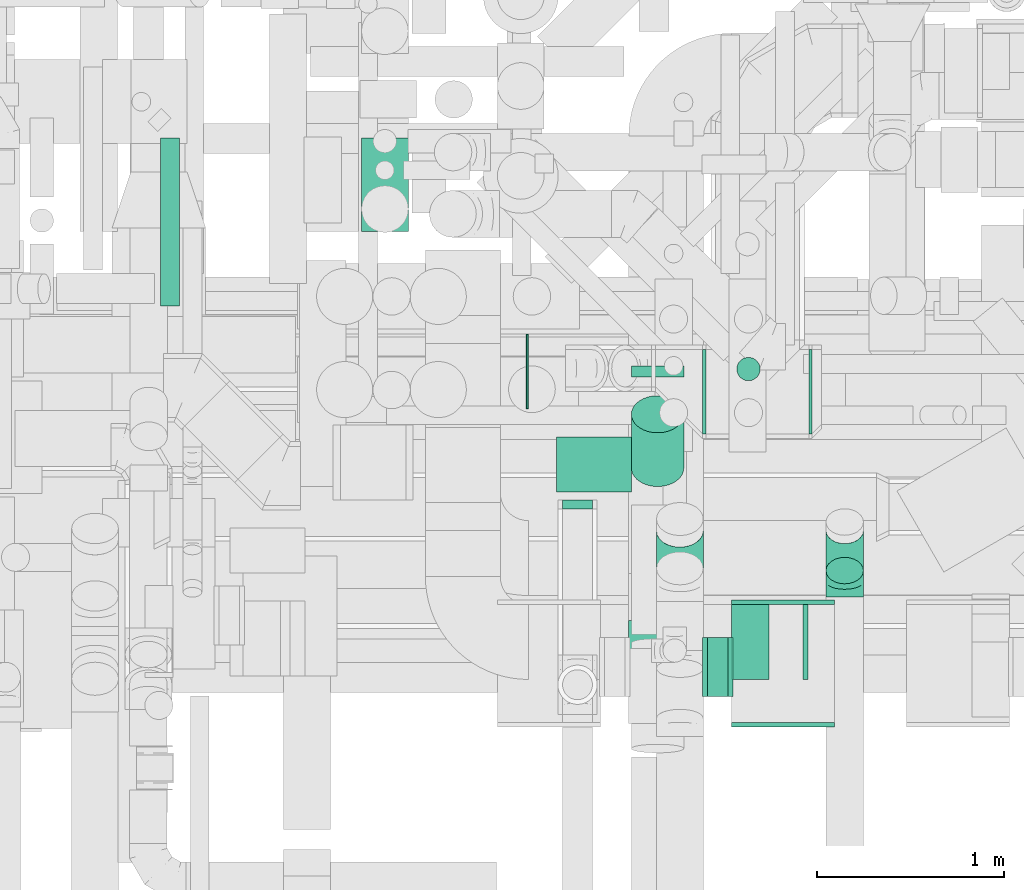
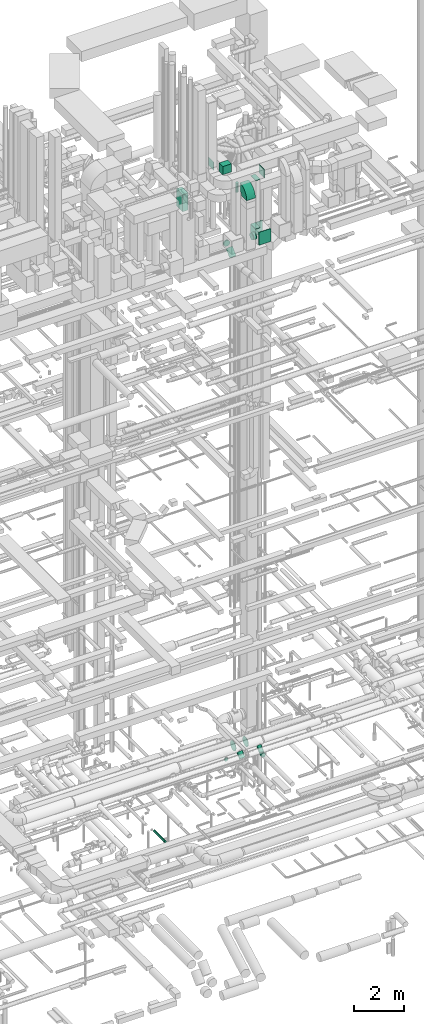
# One storey, part 223 of 337: 12 flow segments, 10 flow fittings.
"""IFC2X3 building model written with IfcOpenShell, lengths in millimetres."""

from ifc_helpers import new_model, entity, si_unit, converted_unit, derived_unit, direction, frame, frame_2d, origin, origin_2d_with_axis, place, context, subcontext, project, spatial, polyline, circle_curve, parameter, trimmed, segment, composite_curve, rectangle, circle, outline, extrude, faceted_brep, source, transform, mapped, material, type_object, type_shapes, element, save


model = new_model("IFC2X3")

# Units and contexts
model_context = context("Model", 3, precision=0.01, world=origin(), true_north=direction((6.12303176911189e-17, 1.0)))
body_context = subcontext(model_context, "Body", "Model", "MODEL_VIEW")
ifc_project = project(units=[si_unit("LENGTHUNIT", "METRE", prefix="MILLI"), si_unit("AREAUNIT", "SQUARE_METRE"), si_unit("VOLUMEUNIT", "CUBIC_METRE"), converted_unit("PLANEANGLEUNIT", "DEGREE", entity("IfcRatioMeasure", 0.0174532925199433), si_unit("PLANEANGLEUNIT", "RADIAN"), dimensions=[0, 0, 0, 0, 0, 0, 0]), si_unit("MASSUNIT", "GRAM", prefix="KILO"), derived_unit("MASSDENSITYUNIT", [(si_unit("MASSUNIT", "GRAM", prefix="KILO"), 1), (si_unit("LENGTHUNIT", "METRE"), -3)]), derived_unit("MOMENTOFINERTIAUNIT", [(si_unit("LENGTHUNIT", "METRE"), 4)]), si_unit("TIMEUNIT", "SECOND"), si_unit("FREQUENCYUNIT", "HERTZ"), si_unit("THERMODYNAMICTEMPERATUREUNIT", "DEGREE_CELSIUS"), derived_unit("THERMALTRANSMITTANCEUNIT", [(si_unit("MASSUNIT", "GRAM", prefix="KILO"), 1), (si_unit("THERMODYNAMICTEMPERATUREUNIT", "KELVIN"), -1), (si_unit("TIMEUNIT", "SECOND"), -3)]), derived_unit("VOLUMETRICFLOWRATEUNIT", [(si_unit("LENGTHUNIT", "METRE"), 3), (si_unit("TIMEUNIT", "SECOND"), -1)]), derived_unit("MASSFLOWRATEUNIT", [(si_unit("MASSUNIT", "GRAM", prefix="KILO"), 1), (si_unit("TIMEUNIT", "SECOND"), -1)]), derived_unit("ROTATIONALFREQUENCYUNIT", [(si_unit("TIMEUNIT", "SECOND"), -1)]), si_unit("ELECTRICCURRENTUNIT", "AMPERE"), si_unit("ELECTRICVOLTAGEUNIT", "VOLT"), si_unit("POWERUNIT", "WATT"), si_unit("FORCEUNIT", "NEWTON", prefix="KILO"), si_unit("ILLUMINANCEUNIT", "LUX"), si_unit("LUMINOUSFLUXUNIT", "LUMEN"), si_unit("LUMINOUSINTENSITYUNIT", "CANDELA"), derived_unit("USERDEFINED", [(si_unit("MASSUNIT", "GRAM", prefix="KILO"), -1), (si_unit("LENGTHUNIT", "METRE"), -2), (si_unit("TIMEUNIT", "SECOND"), 3), (si_unit("LUMINOUSFLUXUNIT", "LUMEN"), 1)]), derived_unit("LINEARVELOCITYUNIT", [(si_unit("LENGTHUNIT", "METRE"), 1), (si_unit("TIMEUNIT", "SECOND"), -1)]), si_unit("PRESSUREUNIT", "PASCAL"), derived_unit("USERDEFINED", [(si_unit("LENGTHUNIT", "METRE"), -2), (si_unit("MASSUNIT", "GRAM", prefix="KILO"), 1), (si_unit("TIMEUNIT", "SECOND"), -2)]), derived_unit("LINEARFORCEUNIT", [(si_unit("MASSUNIT", "GRAM", prefix="KILO"), 1), (si_unit("LENGTHUNIT", "METRE"), 1), (si_unit("TIMEUNIT", "SECOND"), -2), (si_unit("LENGTHUNIT", "METRE"), -1)]), derived_unit("PLANARFORCEUNIT", [(si_unit("MASSUNIT", "GRAM", prefix="KILO"), 1), (si_unit("LENGTHUNIT", "METRE"), 1), (si_unit("TIMEUNIT", "SECOND"), -2), (si_unit("LENGTHUNIT", "METRE"), -2)])], contexts=[model_context])

# Site, building, storey
site_placement = place(None, origin())
site = spatial("IfcSite", under=ifc_project, at=site_placement, CompositionType="ELEMENT")
building_placement = place(site_placement, origin())
building = spatial("IfcBuilding", under=site, at=building_placement, CompositionType="ELEMENT")
storey_placement = place(building_placement, origin())
storey = spatial("IfcBuildingStorey", under=building, at=storey_placement, CompositionType="ELEMENT", Elevation=0.0)

# Flow segments
duct_segment_type_1 = type_object("IfcDuctSegmentType", PredefinedType="NOTDEFINED")
flow_segment_1_placement = place(storey_placement, frame((55470.02, 10580.6, 29220.0)))
element("IfcFlowSegment", 1, at=flow_segment_1_placement, inside=storey, type_object=duct_segment_type_1, context=body_context, shape_type="SweptSolid", body=[
    extrude(rectangle(XDim=249.999999999995, YDim=499.999999999999, at=origin_2d_with_axis()), frame((125.0, 250.0, 0.0)), (0.0, 0.0, 1.0), 828.55629679781),
])
flow_segment_2_placement = place(storey_placement, frame((56510.5, 9188.29, 31500.0)))
element("IfcFlowSegment", 2, at=flow_segment_2_placement, inside=storey, type_object=duct_segment_type_1, context=body_context, shape_type="SweptSolid", body=[
    extrude(rectangle(XDim=294.71122000001, YDim=399.999999999996, at=origin_2d_with_axis()), frame((200.0, 147.36, 0.0), z_axis=(0.0, 0.0, 1.0), x_axis=(0.0, 1.0, 0.0)), (0.0, 0.0, 1.0), 399.999999999996),
])
flow_segment_3_placement = place(storey_placement, frame((56350.5, 9633.0, 31500.0)))
element("IfcFlowSegment", 3, at=flow_segment_3_placement, inside=storey, type_object=duct_segment_type_1, context=body_context, shape_type="SweptSolid", body=[
    extrude(rectangle(XDim=10.0000000000324, YDim=400.0, at=origin_2d_with_axis()), frame((5.0, 200.0, 0.0), z_axis=(0.0, 0.0, 1.0), x_axis=(-1.0, 0.0, 0.0)), (0.0, 0.0, 1.0), 399.999999999996),
])
duct_segment_type_2 = type_object("IfcDuctSegmentType", PredefinedType="NOTDEFINED")
flow_segment_4_placement = place(storey_placement, frame((54395.31, 10183.58, -836.6)))
element("IfcFlowSegment", 4, at=flow_segment_4_placement, inside=storey, type_object=duct_segment_type_2, context=body_context, shape_type="SweptSolid", body=[
    extrude(circle(Radius=50.0, at=origin_2d_with_axis()), frame((51.6, 0.0, 51.6), z_axis=(0.0, 1.0, 0.0), x_axis=(1.0, 0.0, 0.0)), (0.0, 0.0, 1.0), 895.739513762699),
])
flow_segment_5_placement = place(storey_placement, frame((57317.0, 8097.11, 28635.9)))
element("IfcFlowSegment", 5, at=flow_segment_5_placement, inside=storey, type_object=duct_segment_type_2, context=body_context, shape_type="SweptSolid", body=[
    extrude(circle(Radius=157.5, at=origin_2d_with_axis()), frame((0.0, 159.1, 159.1), z_axis=(1.0, 0.0, 0.0), x_axis=(0.0, 1.0, 0.0)), (0.0, 0.0, 1.0), 110.000049999996),
])
flow_segment_6_placement = place(storey_placement, frame((57472.4, 9781.72, 29920.0)))
element("IfcFlowSegment", 6, at=flow_segment_6_placement, inside=storey, type_object=duct_segment_type_2, context=body_context, shape_type="SweptSolid", body=[
    extrude(circle(Radius=62.5, at=origin_2d_with_axis()), frame((64.1, 64.1, 0.0)), (0.0, 0.0, 1.0), 454.999999999996),
])
flow_segment_7_placement = place(storey_placement, frame((56909.56, 9802.66, 27468.4)))
element("IfcFlowSegment", 7, at=flow_segment_7_placement, inside=storey, type_object=duct_segment_type_2, context=body_context, shape_type="SweptSolid", body=[
    extrude(circle(Radius=140.0, at=origin_2d_with_axis()), frame((141.6, 0.0, 141.6), z_axis=(0.0, 1.0, 0.0), x_axis=(-1.0, 0.0, 0.0)), (0.0, 0.0, 1.0), 59.7402025355326),
])
flow_segment_8_placement = place(storey_placement, frame((56909.56, 9216.83, 27140.14)))
element("IfcFlowSegment", 8, at=flow_segment_8_placement, inside=storey, type_object=duct_segment_type_2, context=body_context, shape_type="SweptSolid", body=[
    extrude(circle(Radius=140.0, at=origin_2d_with_axis()), frame((141.6, 100.59, 100.59), z_axis=(0.0, 0.707106781186524, 0.707106781186571), x_axis=(-1.0, 0.0, 0.0)), (0.0, 0.0, 1.0), 406.241937235369),
])
flow_segment_9_placement = place(storey_placement, frame((57948.72, 8697.4, 3086.28)))
element("IfcFlowSegment", 9, at=flow_segment_9_placement, inside=storey, type_object=duct_segment_type_2, context=body_context, shape_type="SweptSolid", body=[
    extrude(circle(Radius=100.0, at=origin_2d_with_axis()), frame((101.6, 72.31, 72.3), z_axis=(0.0, 0.707050721093122, 0.707162836835828), x_axis=(-1.0, 0.0, 0.0)), (0.0, 0.0, 1.0), 303.612654373736),
])
flow_segment_10_placement = place(storey_placement, frame((57860.12, 9498.4, 2939.23)))
element("IfcFlowSegment", 10, at=flow_segment_10_placement, inside=storey, type_object=duct_segment_type_2, context=body_context, shape_type="SweptSolid", body=[
    extrude(circle(Radius=225.0, at=origin_2d_with_axis()), frame((0.0, 226.6, 226.6), z_axis=(1.0, 0.0, 0.0), x_axis=(0.0, -1.0, 0.0)), (0.0, 0.0, 1.0), 15.1999000000066),
])
flow_segment_11_placement = place(storey_placement, frame((57291.08, 9498.4, 2939.23)))
element("IfcFlowSegment", 11, at=flow_segment_11_placement, inside=storey, type_object=duct_segment_type_2, context=body_context, shape_type="SweptSolid", body=[
    extrude(circle(Radius=225.0, at=origin_2d_with_axis()), frame((0.0, 226.6, 226.6), z_axis=(1.0, 0.0, 0.0), x_axis=(0.0, 1.0, 0.0)), (0.0, 0.0, 1.0), 19.0398593203591),
])
flow_segment_12_placement = place(storey_placement, frame((57043.49, 8691.86, 3083.24)))
element("IfcFlowSegment", 12, at=flow_segment_12_placement, inside=storey, type_object=duct_segment_type_2, context=body_context, shape_type="SweptSolid", body=[
    extrude(circle(Radius=125.0, at=origin_2d_with_axis()), frame((126.6, 89.98, 89.98), z_axis=(0.0, 0.707106781186498, 0.707106781186597), x_axis=(1.0, 0.0, 0.0)), (0.0, 0.0, 1.0), 284.661967366003),
])

# Flow fittings
ifc_material = material()
duct_fitting_type_1 = type_object("IfcDuctFittingType", PredefinedType="NOTDEFINED", material=ifc_material)
shared_shape_1 = source(origin(), body_context, "Body", "SweptSolid", [
    extrude(rectangle(XDim=200.0, YDim=26.096, at=origin_2d_with_axis()), frame((6.95, 0.0, -200.0), z_axis=(0.0, 0.0, 1.0), x_axis=(0.0, -1.0, 0.0)), (0.0, 0.0, 1.0), 400.0),
])
type_shapes(duct_fitting_type_1, [shared_shape_1])
for number, where, z_axis, x_axis in (
    (13, (57547.0, 8388.29, 29132.0), (0.0, 1.0, 0.0), (0.0, 0.0, 1.0)),
    (14, (57547.0, 8388.29, 31500.0), (0.0, 1.0, 0.0), (0.0, 0.0, -1.0)),
):
    element("IfcFlowFitting", number, at=place(storey_placement, frame(where, z_axis=z_axis, x_axis=x_axis)), inside=storey, type_object=duct_fitting_type_1, material=ifc_material, context=body_context, shape_type="MappedRepresentation", body=[
        mapped(shared_shape_1, transform((0.0, 0.0, 0.0), scale=1.0)),
    ])
duct_fitting_type_2 = type_object("IfcDuctFittingType", PredefinedType="NOTDEFINED", material=ifc_material)
shared_shape_2 = source(origin(), body_context, "Body", "SweptSolid", [
    extrude(rectangle(XDim=24.9999999999999, YDim=400.0, at=origin_2d_with_axis()), frame((12.5, 0.0, -200.0)), (0.0, 0.0, 1.0), 400.0),
])
type_shapes(duct_fitting_type_2, [shared_shape_2])
flow_fitting_1_placement = place(storey_placement, frame((57828.5, 8388.29, 31700.0)))
element("IfcFlowFitting", 15, at=flow_fitting_1_placement, inside=storey, type_object=duct_fitting_type_2, material=ifc_material, context=body_context, shape_type="MappedRepresentation", body=[
    mapped(shared_shape_2, transform((0.0, 0.0, 0.0), scale=1.0)),
])
duct_fitting_type_3 = type_object("IfcDuctFittingType", PredefinedType="NOTDEFINED", material=ifc_material)
shared_shape_3 = source(origin(), body_context, "Body", "SweptSolid", [
    extrude(rectangle(XDim=24.9999999999999, YDim=550.0, at=origin_2d_with_axis()), frame((12.5, 0.0, -315.0)), (0.0, 0.0, 1.0), 630.0),
])
type_shapes(duct_fitting_type_3, [shared_shape_3])
for number, where, z_axis, x_axis in (
    (16, (57722.0, 7958.29, 28817.0), (0.0, 0.0, 1.0), (0.0, -1.0, 0.0)),
    (17, (57722.0, 8588.29, 28817.0), (0.0, 0.0, 1.0), (0.0, 1.0, 0.0)),
):
    element("IfcFlowFitting", number, at=place(storey_placement, frame(where, z_axis=z_axis, x_axis=x_axis)), inside=storey, type_object=duct_fitting_type_3, material=ifc_material, context=body_context, shape_type="MappedRepresentation", body=[
        mapped(shared_shape_3, transform((0.0, 0.0, 0.0), scale=1.0)),
    ])
duct_fitting_type_4 = type_object("IfcDuctFittingType", PredefinedType="NOTDEFINED", material=ifc_material)
shared_shape_4 = source(origin(), body_context, "Body", "Brep", [
    faceted_brep([(-82.84, 0.0, -100.0), (-82.84, -25.88, -96.59), (-82.84, -50.0, -86.6), (-82.84, -70.71, -70.71), (-82.84, -86.6, -50.0), (-82.84, -96.59, -25.88), (-82.84, -100.0, 0.0), (-82.84, -96.59, 25.88), (-82.84, -86.6, 50.0), (-82.84, -70.71, 70.71), (-82.84, -50.0, 86.6), (-82.84, -25.88, 96.59), (-82.84, 0.0, 100.0), (-82.84, 25.88, 96.59), (-82.84, 50.0, 86.6), (-82.84, 70.71, 70.71), (-82.84, 86.6, 50.0), (-82.84, 96.59, 25.88), (-82.84, 100.0, 0.0), (-82.84, 96.59, -25.88), (-82.84, 86.6, -50.0), (-82.84, 70.71, -70.71), (-82.84, 50.0, -86.6), (-82.84, 25.88, -96.59), (-10.72, 25.88, 96.59), (-20.71, 50.0, 86.6), (0.0, 0.0, 100.0), (-29.29, 70.71, 70.71), (-35.87, 86.6, 50.0), (-40.01, 96.59, 25.88), (-41.42, 100.0, 0.0), (-40.01, 96.59, -25.88), (-35.87, 86.6, -50.0), (-29.29, 70.71, -70.71), (-10.72, 25.88, -96.59), (0.0, 0.0, -100.0), (-20.71, 50.0, -86.6), (10.72, -25.88, -96.59), (20.71, -50.0, -86.6), (29.29, -70.71, -70.71), (35.87, -86.6, -50.0), (40.01, -96.59, -25.88), (41.42, -100.0, 0.0), (40.01, -96.59, 25.88), (35.87, -86.6, 50.0), (29.29, -70.71, 70.71), (20.71, -50.0, 86.6), (10.72, -25.88, 96.59), (58.58, 58.58, 100.0), (40.28, 76.88, 96.59), (23.22, 93.93, 86.6), (8.58, 108.58, 70.71), (-2.66, 119.82, 50.0), (-9.72, 126.88, 25.88), (-12.13, 129.29, 0.0), (-9.72, 126.88, -25.88), (-2.66, 119.82, -50.0), (8.58, 108.58, -70.71), (23.22, 93.93, -86.6), (40.28, 76.88, -96.59), (58.58, 58.58, -100.0), (76.88, 40.28, -96.59), (93.93, 23.22, -86.6), (108.58, 8.58, -70.71), (119.82, -2.66, -50.0), (126.88, -9.72, -25.88), (129.29, -12.13, 0.0), (126.88, -9.72, 25.88), (119.82, -2.66, 50.0), (108.58, 8.58, 70.71), (93.93, 23.22, 86.6), (76.88, 40.28, 96.59)], [[[0, 1, 2, 3, 4, 5, 6, 7, 8, 9, 10, 11, 12, 13, 14, 15, 16, 17, 18, 19, 20, 21, 22, 23]], [[24, 25, 14, 13]], [[26, 24, 13, 12]], [[14, 25, 27, 15]], [[28, 29, 17, 16]], [[28, 16, 15, 27]], [[30, 18, 17, 29]], [[31, 32, 20, 19]], [[30, 31, 19, 18]], [[32, 33, 21, 20]], [[34, 35, 0, 23]], [[36, 34, 23, 22]], [[33, 36, 22, 21]], [[1, 0, 35, 37]], [[2, 1, 37, 38]], [[38, 39, 3, 2]], [[5, 4, 40, 41]], [[6, 5, 41, 42]], [[39, 40, 4, 3]], [[6, 42, 43, 7]], [[7, 43, 44, 8]], [[8, 44, 45, 9]], [[9, 45, 46, 10]], [[10, 46, 47, 11]], [[26, 12, 11, 47]], [[24, 26, 48, 49]], [[25, 24, 49, 50]], [[27, 25, 50, 51]], [[29, 28, 52, 53]], [[30, 29, 53, 54]], [[51, 52, 28, 27]], [[30, 54, 55, 31]], [[31, 55, 56, 32]], [[57, 33, 32, 56]], [[36, 58, 59, 34]], [[34, 59, 60, 35]], [[58, 36, 33, 57]], [[35, 60, 61, 37]], [[37, 61, 62, 38]], [[63, 39, 38, 62]], [[40, 64, 65, 41]], [[41, 65, 66, 42]], [[64, 40, 39, 63]], [[43, 42, 66, 67]], [[44, 43, 67, 68]], [[68, 69, 45, 44]], [[47, 46, 70, 71]], [[26, 47, 71, 48]], [[69, 70, 46, 45]], [[59, 58, 57, 56, 55, 54, 53, 52, 51, 50, 49, 48, 71, 70, 69, 68, 67, 66, 65, 64, 63, 62, 61, 60]]]),
])
type_shapes(duct_fitting_type_4, [shared_shape_4])
flow_fitting_2_placement = place(storey_placement, frame((58050.32, 8711.14, 3100.0), z_axis=(-1.0, 0.0, 0.0), x_axis=(0.0, -0.707106781186502, -0.707106781186593)))
element("IfcFlowFitting", 18, at=flow_fitting_2_placement, inside=storey, type_object=duct_fitting_type_4, material=ifc_material, context=body_context, shape_type="MappedRepresentation", body=[
    mapped(shared_shape_4, transform((0.0, 0.0, 0.0), scale=1.0)),
])
duct_fitting_type_5 = type_object("IfcDuctFittingType", PredefinedType="NOTDEFINED", material=ifc_material)
shared_shape_5 = source(origin(), body_context, "Body", "Brep", [
    faceted_brep([(20.0, 40.76, -152.13), (20.0, 78.75, -136.4), (20.0, 111.37, -111.37), (20.0, 136.4, -78.75), (20.0, 152.13, -40.76), (20.0, 157.5, 0.0), (20.0, 152.13, 40.76), (20.0, 136.4, 78.75), (20.0, 111.37, 111.37), (20.0, 78.75, 136.4), (20.0, 40.76, 152.13), (20.0, 0.0, 157.5), (20.0, -40.76, 152.13), (20.0, -78.75, 136.4), (20.0, -111.37, 111.37), (20.0, -136.4, 78.75), (20.0, -152.13, 40.76), (20.0, -157.5, 0.0), (20.0, -152.13, -40.76), (20.0, -136.4, -78.75), (20.0, -111.37, -111.37), (20.0, -78.75, -136.4), (20.0, -40.76, -152.13), (20.0, 0.0, -157.5), (0.0, 0.0, 157.5), (0.0, 40.76, 152.13), (-6.1, 40.76, 152.13), (-6.1, 0.0, 157.5), (0.0, 78.75, 136.4), (-6.1, 78.75, 136.4), (0.0, 111.37, 111.37), (-6.1, 111.37, 111.37), (0.0, 136.4, 78.75), (0.0, 152.13, 40.76), (-6.1, 152.13, 40.76), (-6.1, 136.4, 78.75), (0.0, 157.5, 0.0), (-6.1, 157.5, 0.0), (0.0, 152.13, -40.76), (-6.1, 152.13, -40.76), (0.0, 136.4, -78.75), (-6.1, 136.4, -78.75), (0.0, 111.37, -111.37), (-6.1, 111.37, -111.37), (0.0, 0.0, -157.5), (-6.1, 0.0, -157.5), (-6.1, 40.76, -152.13), (0.0, 40.76, -152.13), (-6.1, 78.75, -136.4), (0.0, 78.75, -136.4), (0.0, -40.76, -152.13), (-6.1, -40.76, -152.13), (0.0, -78.75, -136.4), (-6.1, -78.75, -136.4), (0.0, -111.37, -111.37), (-6.1, -111.37, -111.37), (0.0, -136.4, -78.75), (0.0, -152.13, -40.76), (-6.1, -152.13, -40.76), (-6.1, -136.4, -78.75), (0.0, -157.5, 0.0), (-6.1, -157.5, 0.0), (0.0, -152.13, 40.76), (-6.1, -152.13, 40.76), (0.0, -136.4, 78.75), (-6.1, -136.4, 78.75), (0.0, -111.37, 111.37), (-6.1, -111.37, 111.37), (0.0, -78.75, 136.4), (0.0, -40.76, 152.13), (-6.1, -40.76, 152.13), (-6.1, -78.75, 136.4)], [[[0, 1, 2, 3, 4, 5, 6, 7, 8, 9, 10, 11, 12, 13, 14, 15, 16, 17, 18, 19, 20, 21, 22, 23]], [[24, 11, 10, 25, 26, 27]], [[25, 10, 9, 28, 29, 26]], [[28, 9, 8, 30, 31, 29]], [[32, 7, 6, 33, 34, 35]], [[33, 6, 5, 36, 37, 34]], [[30, 8, 7, 32, 35, 31]], [[36, 5, 4, 38, 39, 37]], [[38, 4, 3, 40, 41, 39]], [[40, 3, 2, 42, 43, 41]], [[0, 23, 44, 45, 46, 47]], [[1, 0, 47, 46, 48, 49]], [[49, 48, 43, 42, 2, 1]], [[44, 23, 22, 50, 51, 45]], [[50, 22, 21, 52, 53, 51]], [[52, 21, 20, 54, 55, 53]], [[56, 19, 18, 57, 58, 59]], [[57, 18, 17, 60, 61, 58]], [[54, 20, 19, 56, 59, 55]], [[60, 17, 16, 62, 63, 61]], [[62, 16, 15, 64, 65, 63]], [[64, 15, 14, 66, 67, 65]], [[68, 13, 12, 69, 70, 71]], [[69, 12, 11, 24, 27, 70]], [[66, 14, 13, 68, 71, 67]], [[45, 51, 53, 55, 59, 58, 61, 63, 65, 67, 71, 70, 27, 26, 29, 31, 35, 34, 37, 39, 41, 43, 48, 46]]]),
])
type_shapes(duct_fitting_type_5, [shared_shape_5])
for number, where, z_axis, x_axis in (
    (19, (57447.0, 8256.2, 28795.0), (0.0, 0.0, -1.0), (-1.0, 0.0, 0.0)),
    (20, (57297.0, 8256.2, 28795.0), (0.0, -1.0, 0.0), (1.0, 0.0, 0.0)),
):
    element("IfcFlowFitting", number, at=place(storey_placement, frame(where, z_axis=z_axis, x_axis=x_axis)), inside=storey, type_object=duct_fitting_type_5, material=ifc_material, context=body_context, shape_type="MappedRepresentation", body=[
        mapped(shared_shape_5, transform((0.0, 0.0, 0.0), scale=1.0)),
    ])
duct_fitting_type_6 = type_object("IfcDuctFittingType", PredefinedType="NOTDEFINED", material=ifc_material)
shared_shape_6 = source(origin(), body_context, "Body", "Brep", [
    faceted_brep([(20.0, 20.71, -77.27), (20.0, 40.0, -69.28), (20.0, 56.57, -56.57), (20.0, 69.28, -40.0), (20.0, 77.27, -20.71), (20.0, 80.0, 0.0), (20.0, 77.27, 20.71), (20.0, 69.28, 40.0), (20.0, 56.57, 56.57), (20.0, 40.0, 69.28), (20.0, 20.71, 77.27), (20.0, 0.0, 80.0), (20.0, -20.71, 77.27), (20.0, -40.0, 69.28), (20.0, -56.57, 56.57), (20.0, -69.28, 40.0), (20.0, -77.27, 20.71), (20.0, -80.0, 0.0), (20.0, -77.27, -20.71), (20.0, -69.28, -40.0), (20.0, -56.57, -56.57), (20.0, -40.0, -69.28), (20.0, -20.71, -77.27), (20.0, 0.0, -80.0), (0.0, 0.0, 80.0), (0.0, 20.71, 77.27), (-27.93, 20.71, 77.27), (-27.93, 0.0, 80.0), (0.0, 40.0, 69.28), (-27.93, 40.0, 69.28), (0.0, 56.57, 56.57), (-27.93, 56.57, 56.57), (0.0, 69.28, 40.0), (0.0, 77.27, 20.71), (-27.93, 77.27, 20.71), (-27.93, 69.28, 40.0), (0.0, 80.0, 0.0), (-27.93, 80.0, 0.0), (0.0, 77.27, -20.71), (-27.93, 77.27, -20.71), (0.0, 69.28, -40.0), (-27.93, 69.28, -40.0), (0.0, 56.57, -56.57), (-27.93, 56.57, -56.57), (0.0, 40.0, -69.28), (0.0, 20.71, -77.27), (-27.93, 20.71, -77.27), (-27.93, 40.0, -69.28), (0.0, 0.0, -80.0), (-27.93, 0.0, -80.0), (0.0, -20.71, -77.27), (-27.93, -20.71, -77.27), (0.0, -40.0, -69.28), (-27.93, -40.0, -69.28), (0.0, -56.57, -56.57), (-27.93, -56.57, -56.57), (0.0, -69.28, -40.0), (0.0, -77.27, -20.71), (-27.93, -77.27, -20.71), (-27.93, -69.28, -40.0), (0.0, -80.0, 0.0), (-27.93, -80.0, 0.0), (0.0, -77.27, 20.71), (-27.93, -77.27, 20.71), (0.0, -69.28, 40.0), (-27.93, -69.28, 40.0), (0.0, -56.57, 56.57), (-27.93, -56.57, 56.57), (0.0, -40.0, 69.28), (0.0, -20.71, 77.27), (-27.93, -20.71, 77.27), (-27.93, -40.0, 69.28)], [[[0, 1, 2, 3, 4, 5, 6, 7, 8, 9, 10, 11, 12, 13, 14, 15, 16, 17, 18, 19, 20, 21, 22, 23]], [[24, 11, 10, 25, 26, 27]], [[25, 10, 9, 28, 29, 26]], [[28, 9, 8, 30, 31, 29]], [[32, 7, 6, 33, 34, 35]], [[33, 6, 5, 36, 37, 34]], [[30, 8, 7, 32, 35, 31]], [[36, 5, 4, 38, 39, 37]], [[38, 4, 3, 40, 41, 39]], [[40, 3, 2, 42, 43, 41]], [[44, 1, 0, 45, 46, 47]], [[45, 0, 23, 48, 49, 46]], [[42, 2, 1, 44, 47, 43]], [[48, 23, 22, 50, 51, 49]], [[50, 22, 21, 52, 53, 51]], [[52, 21, 20, 54, 55, 53]], [[56, 19, 18, 57, 58, 59]], [[57, 18, 17, 60, 61, 58]], [[54, 20, 19, 56, 59, 55]], [[60, 17, 16, 62, 63, 61]], [[62, 16, 15, 64, 65, 63]], [[64, 15, 14, 66, 67, 65]], [[68, 13, 12, 69, 70, 71]], [[69, 12, 11, 24, 27, 70]], [[66, 14, 13, 68, 71, 67]], [[49, 51, 53, 55, 59, 58, 61, 63, 65, 67, 71, 70, 27, 26, 29, 31, 35, 34, 37, 39, 41, 43, 47, 46]]]),
])
type_shapes(duct_fitting_type_6, [shared_shape_6])
flow_fitting_3_placement = place(storey_placement, frame((56623.29, 9118.38, 3100.0), z_axis=(0.0, 0.0, 1.0), x_axis=(0.0, -1.0, 0.0)))
element("IfcFlowFitting", 21, at=flow_fitting_3_placement, inside=storey, type_object=duct_fitting_type_6, material=ifc_material, context=body_context, shape_type="MappedRepresentation", body=[
    mapped(shared_shape_6, transform((0.0, 0.0, 0.0), scale=1.0)),
])
duct_fitting_type_7 = type_object("IfcDuctFittingType", PredefinedType="NOTDEFINED", material=ifc_material)
shared_shape_7 = source(origin(), body_context, "Body", "SweptSolid", [
    extrude(outline(composite_curve([segment(polyline([(-375.0, -175.0), (25.0, -175.0)]), True, "CONTINUOUS"), segment(trimmed(circle_curve(frame_2d((175.0, -175.0), x_axis=(-1.90059950000432e-08, 1.0)), 150.0), [parameter(0.0)], [parameter(89.9999989110367)], True, "PARAMETER"), False, "CONTINUOUS"), segment(polyline([(175.0, -25.0), (175.0, 375.0)]), True, "CONTINUOUS"), segment(trimmed(circle_curve(frame_2d((175.0, -175.0), x_axis=(-1.90059950000432e-08, 1.0)), 550.0), [parameter(0.0)], [parameter(89.9999989110367)], True, "PARAMETER"), True, "CONTINUOUS")], self_intersect=False)), frame((-175.0, 175.0, -200.0), z_axis=(0.0, 0.0, 1.0), x_axis=(-1.0, 1.90059958864453e-08, 0.0)), (0.0, 0.0, 1.0), 400.0),
])
type_shapes(duct_fitting_type_7, [shared_shape_7])
flow_fitting_4_placement = place(storey_placement, frame((57097.0, 8154.29, 31200.0), z_axis=(1.0, 0.0, 0.0), x_axis=(0.0, -1.0, -1.90059958557437e-08)))
element("IfcFlowFitting", 22, at=flow_fitting_4_placement, inside=storey, type_object=duct_fitting_type_7, material=ifc_material, context=body_context, shape_type="MappedRepresentation", body=[
    mapped(shared_shape_7, transform((0.0, 0.0, 0.0), scale=1.0)),
])

save(model, "model.ifc")
